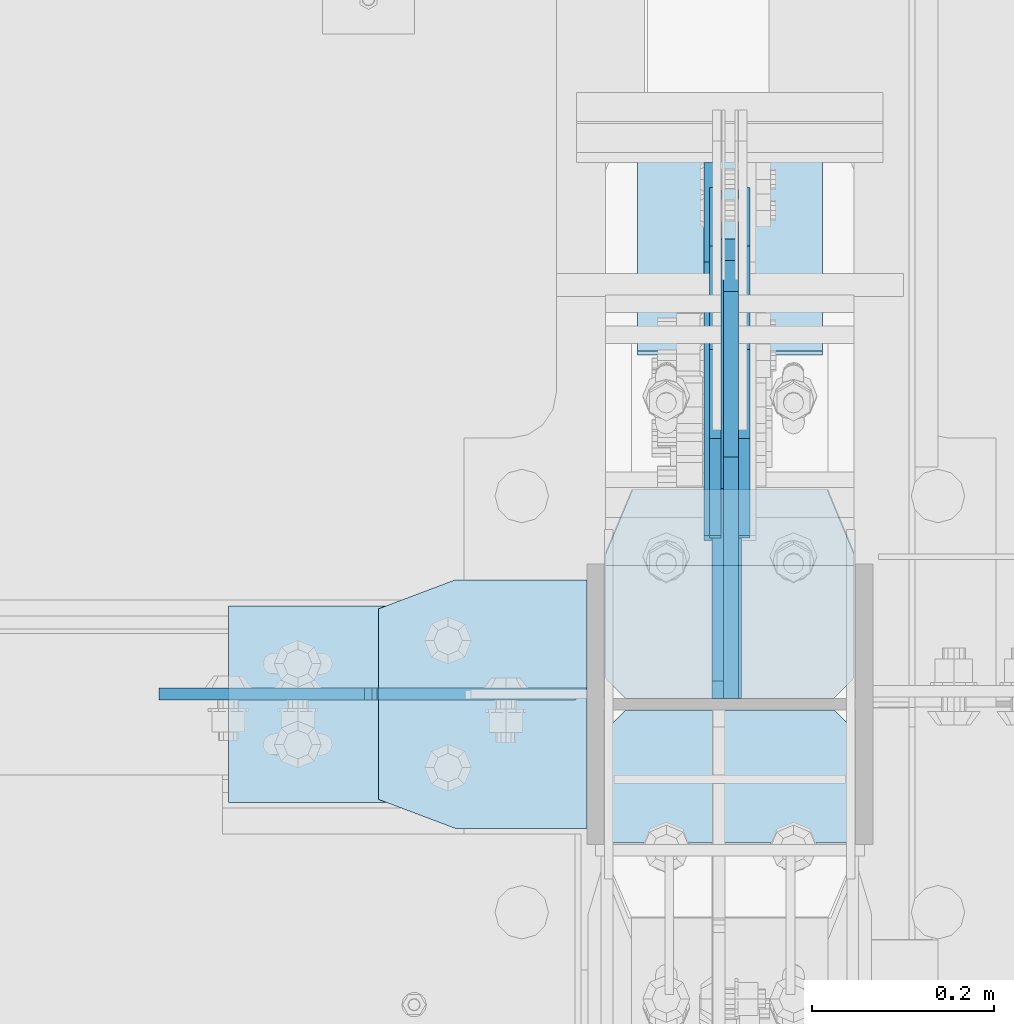
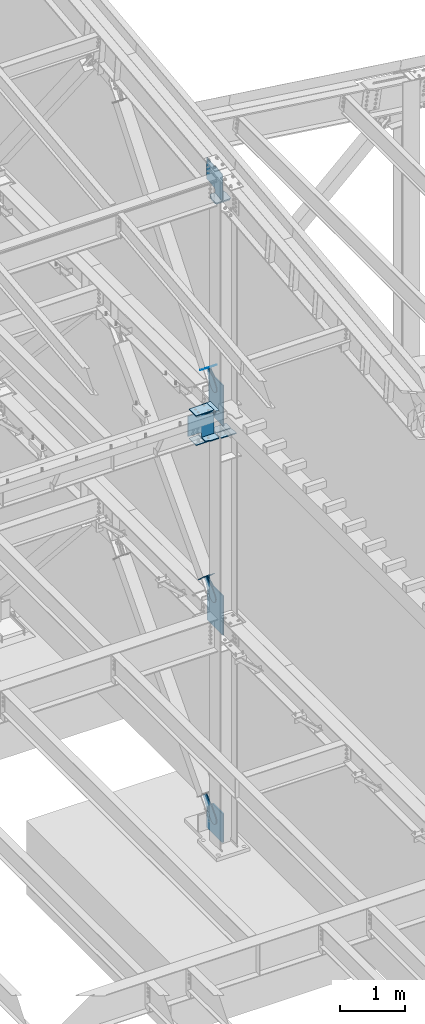
# One storey, part 1045 of 1179: 19 plates, 8 elements without a shape of their own.
"""IFC2X3 building model written with IfcOpenShell, lengths in millimetres."""

from ifc_helpers import new_model, si_unit, frame, origin_with_axes, place, context, subcontext, project, spatial, faceted_brep, material, type_object, element, aggregate, save


model = new_model("IFC2X3")

# Units and contexts
model_context = context("Model", 3, precision=1e-05, world=origin_with_axes())
body_context = subcontext(model_context, "Body", "Model", "MODEL_VIEW")
ifc_project = project(units=[si_unit("LENGTHUNIT", "METRE", prefix="MILLI"), si_unit("AREAUNIT", "SQUARE_METRE"), si_unit("VOLUMEUNIT", "CUBIC_METRE"), si_unit("MASSUNIT", "GRAM", prefix="KILO"), si_unit("TIMEUNIT", "SECOND"), si_unit("PLANEANGLEUNIT", "RADIAN"), si_unit("SOLIDANGLEUNIT", "STERADIAN"), si_unit("THERMODYNAMICTEMPERATUREUNIT", "DEGREE_CELSIUS"), si_unit("LUMINOUSINTENSITYUNIT", "LUMEN")], contexts=[model_context])

# Site, building, storey
site_placement = place(None, origin_with_axes())
site = spatial("IfcSite", under=ifc_project, at=site_placement, CompositionType="ELEMENT")
building_placement = place(site_placement, origin_with_axes())
building = spatial("IfcBuilding", under=site, at=building_placement, Name="Undefined", CompositionType="ELEMENT")
storey_placement = place(building_placement, origin_with_axes())
storey = spatial("IfcBuildingStorey", under=building, at=storey_placement, Name="Undefined", CompositionType="ELEMENT", Elevation=0.0)

# Assembly, plate
assembly_1_placement = place(storey_placement, origin_with_axes())
assembly_1 = element("IfcElementAssembly", 1, at=assembly_1_placement, inside=storey, AssemblyPlace="NOTDEFINED", PredefinedType="RIGID_FRAME")
ifc_material_1 = material(Name="STEEL/A36")
plate_type_1 = type_object("IfcPlateType", PredefinedType="NOTDEFINED")
plate_1_placement = place(assembly_1_placement, frame((24291.925, 27512.4985304241, 8313.50088383657), z_axis=(0.0, -0.784153429306141, 0.620566998242268), x_axis=(0.0, 0.62056699824227, 0.78415342930614)))
plate_1 = element("IfcPlate", 2, at=plate_1_placement, type_object=plate_type_1, material=ifc_material_1, context=body_context, shape_type="Brep", body=[
    faceted_brep([(0.0, -6.34999999999854, 0.0), (-101.600000000211, -6.34999999999854, -44.6881937825565), (-101.600000000211, 6.34999999999854, -44.6881937825565), (0.0, 6.34999999999854, 0.0), (-246.684985848258, -6.34999999999854, -44.6881937827675), (-246.684985848258, 6.34999999999854, -44.6881937827675), (-281.313054102191, -6.34999999999854, -37.800242748639), (-281.313054102191, 6.34999999999854, -37.800242748639), (-310.669312868691, -6.34999999999854, -18.1850177516608), (-310.669312868691, 6.34999999999854, -18.1850177516608), (-330.284537865713, -6.34999999999854, 11.1712410148393), (-330.284537865713, 6.34999999999854, 11.1712410148393), (-337.172488899912, -6.34999999999854, 45.7993031647638), (-337.172488899912, 6.34999999999854, 45.7993031647638), (-330.284537865768, -6.34999999999854, 80.4273714187839), (-330.284537865768, 6.34999999999854, 80.4273714187839), (-310.669312868773, -6.34999999999854, 109.783630185371), (-310.669312868773, 6.34999999999854, 109.783630185371), (-281.313054102271, -6.34999999999854, 129.398855182466), (-281.313054102271, 6.34999999999854, 129.398855182466), (-246.684988899762, -6.34999999999854, 136.286806216707), (-246.684988899762, 6.34999999999854, 136.286806216707), (-101.600000000377, -6.34999999999854, 136.286806216911), (-101.600000000377, 6.34999999999854, 136.286806216911), (-8.18545231595635e-11, -6.34999999999854, 91.5986124346418), (-8.18545231595635e-11, 6.34999999999854, 91.5986124346418), (67.3100000000013, -6.35000000000002, 91.5986124352912), (67.3100000000013, 6.35000000000002, 91.5986124352912), (67.309999999783, -6.35000000000002, -1.09139364212751e-11), (67.309999999783, 6.35000000000002, -1.09139364212751e-11)], [[[0, 1, 2, 3]], [[1, 4, 5, 2]], [[4, 6, 7, 5]], [[6, 8, 9, 7]], [[8, 10, 11, 9]], [[10, 12, 13, 11]], [[12, 14, 15, 13]], [[14, 16, 17, 15]], [[16, 18, 19, 17]], [[18, 20, 21, 19]], [[20, 22, 23, 21]], [[22, 24, 25, 23]], [[24, 26, 27, 25]], [[26, 28, 29, 27]], [[28, 0, 3, 29]], [[5, 7, 9, 11, 13, 15, 17, 19, 21, 23, 25, 27, 29, 3, 2]], [[28, 26, 24, 22, 20, 18, 16, 14, 12, 10, 8, 6, 4, 1, 0]]]),
])
aggregate(assembly_1, [plate_1])

assembly_2_placement = place(storey_placement, origin_with_axes())
assembly_2 = element("IfcElementAssembly", 3, at=assembly_2_placement, inside=storey, AssemblyPlace="NOTDEFINED", PredefinedType="RIGID_FRAME")
plate_2_placement = place(assembly_2_placement, frame((24323.675, 27512.4985304241, 8313.50088383657), z_axis=(0.0, -0.784153429306141, 0.620566998242268), x_axis=(0.0, 0.62056699824227, 0.78415342930614)))
plate_2 = element("IfcPlate", 4, at=plate_2_placement, type_object=plate_type_1, material=ifc_material_1, context=body_context, shape_type="Brep", body=[
    faceted_brep([(0.0, -6.34999999999854, 0.0), (-101.600000000211, -6.34999999999854, -44.6881937825565), (-101.600000000211, 6.34999999999854, -44.6881937825565), (0.0, 6.34999999999854, 0.0), (-246.684985848258, -6.34999999999854, -44.6881937827675), (-246.684985848258, 6.34999999999854, -44.6881937827675), (-281.313054102191, -6.34999999999854, -37.800242748639), (-281.313054102191, 6.34999999999854, -37.800242748639), (-310.669312868691, -6.34999999999854, -18.1850177516608), (-310.669312868691, 6.34999999999854, -18.1850177516608), (-330.284537865713, -6.34999999999854, 11.1712410148393), (-330.284537865713, 6.34999999999854, 11.1712410148393), (-337.172488899912, -6.34999999999854, 45.7993031647638), (-337.172488899912, 6.34999999999854, 45.7993031647638), (-330.284537865768, -6.34999999999854, 80.4273714187839), (-330.284537865768, 6.34999999999854, 80.4273714187839), (-310.669312868773, -6.34999999999854, 109.783630185371), (-310.669312868773, 6.34999999999854, 109.783630185371), (-281.313054102271, -6.34999999999854, 129.398855182466), (-281.313054102271, 6.34999999999854, 129.398855182466), (-246.684988899762, -6.34999999999854, 136.286806216707), (-246.684988899762, 6.34999999999854, 136.286806216707), (-101.600000000377, -6.34999999999854, 136.286806216911), (-101.600000000377, 6.34999999999854, 136.286806216911), (-8.18545231595635e-11, -6.34999999999854, 91.5986124346418), (-8.18545231595635e-11, 6.34999999999854, 91.5986124346418), (67.3100000000013, -6.35000000000002, 91.5986124352912), (67.3100000000013, 6.35000000000002, 91.5986124352912), (67.309999999783, -6.35000000000002, -1.09139364212751e-11), (67.309999999783, 6.35000000000002, -1.09139364212751e-11)], [[[0, 1, 2, 3]], [[1, 4, 5, 2]], [[4, 6, 7, 5]], [[6, 8, 9, 7]], [[8, 10, 11, 9]], [[10, 12, 13, 11]], [[12, 14, 15, 13]], [[14, 16, 17, 15]], [[16, 18, 19, 17]], [[18, 20, 21, 19]], [[20, 22, 23, 21]], [[22, 24, 25, 23]], [[24, 26, 27, 25]], [[26, 28, 29, 27]], [[28, 0, 3, 29]], [[5, 7, 9, 11, 13, 15, 17, 19, 21, 23, 25, 27, 29, 3, 2]], [[28, 26, 24, 22, 20, 18, 16, 14, 12, 10, 8, 6, 4, 1, 0]]]),
])
aggregate(assembly_2, [plate_2])

assembly_3_placement = place(storey_placement, origin_with_axes())
assembly_3 = element("IfcElementAssembly", 5, at=assembly_3_placement, inside=storey, Name="Plate", AssemblyPlace="NOTDEFINED", PredefinedType="RIGID_FRAME")
plate_type_2 = type_object("IfcPlateType", PredefinedType="NOTDEFINED")
plate_3_placement = place(assembly_3_placement, frame((24409.4, 27596.0549002431, 8329.164494984), z_axis=(0.0, -0.784153429306141, 0.620566998242268), x_axis=(-1.0, 0.0, 0.0)))
plate_3 = element("IfcPlate", 6, at=plate_3_placement, type_object=plate_type_2, material=ifc_material_1, Name="Plate", context=body_context, shape_type="Brep", body=[
    faceted_brep([(0.0, -3.17500000000109, 0.0), (0.0, -3.17500000000291, 203.200000000368), (0.0, 3.17499999998836, 203.200000000361), (0.0, 3.17500000000109, 7.27595761418343e-12), (203.199999999997, -3.17500000000291, 203.200000000368), (203.199999999997, 3.17499999998836, 203.200000000361), (203.199999999997, -3.17499999999927, 3.63797880709171e-12), (203.199999999997, 3.17499999999382, -3.63797880709171e-12)], [[[0, 1, 2, 3]], [[1, 4, 5, 2]], [[4, 6, 7, 5]], [[6, 0, 3, 7]], [[5, 7, 3, 2]], [[6, 4, 1, 0]]]),
])
aggregate(assembly_3, [plate_3])

assembly_4_placement = place(storey_placement, origin_with_axes())
assembly_4 = element("IfcElementAssembly", 7, at=assembly_4_placement, inside=storey, Name="Plate", AssemblyPlace="NOTDEFINED", PredefinedType="RIGID_FRAME")
plate_4_placement = place(assembly_4_placement, frame((24409.4, 27649.6818636391, 4382.10915283804), z_axis=(0.0, -0.729241792887682, 0.684256097894611), x_axis=(-1.0, 0.0, 0.0)))
plate_4 = element("IfcPlate", 8, at=plate_4_placement, type_object=plate_type_2, material=ifc_material_1, Name="Plate", context=body_context, shape_type="Brep", body=[
    faceted_brep([(0.0, -3.17500000000109, 0.0), (0.0, -3.17500000000291, 203.200000000368), (0.0, 3.17499999998836, 203.200000000361), (0.0, 3.17500000000109, 7.27595761418343e-12), (203.199999999997, -3.17500000000291, 203.200000000368), (203.199999999997, 3.17499999998836, 203.200000000361), (203.199999999997, -3.17499999999927, 3.63797880709171e-12), (203.199999999997, 3.17499999999382, -3.63797880709171e-12)], [[[0, 1, 2, 3]], [[1, 4, 5, 2]], [[4, 6, 7, 5]], [[6, 0, 3, 7]], [[5, 7, 3, 2]], [[6, 4, 1, 0]]]),
])
aggregate(assembly_4, [plate_4])

# Assembly, plates
assembly_5_placement = place(storey_placement, origin_with_axes())
assembly_5 = element("IfcElementAssembly", 9, at=assembly_5_placement, inside=storey, Name="COLUMN", AssemblyPlace="NOTDEFINED", PredefinedType="RIGID_FRAME")
ifc_material_2 = material(Name="STEEL/A572-GR.50")
plate_type_3 = type_object("IfcPlateType", PredefinedType="NOTDEFINED")
plate_5_placement = place(assembly_5_placement, frame((23922.0377761853, 27187.525, 7489.82500080334), z_axis=(0.0, -1.0, 0.0), x_axis=(1.0, 0.0, 0.0)))
plate_5 = element("IfcPlate", 10, at=plate_5_placement, type_object=plate_type_3, material=ifc_material_2, Name="PLATE", context=body_context, shape_type="Brep", body=[
    faceted_brep([(0.0, -9.52499999999964, 31.75), (-1.45519152283669e-11, -9.52499999999964, 241.299987792969), (1.81898940354586e-11, 9.52499999999964, 241.299987792969), (0.0, 9.52499999999964, 31.75), (84.1374969482276, -9.52499999999691, 273.049987792969), (84.1374969482604, 9.52500000000327, 273.049987792969), (228.599999999984, -9.52499999999054, 273.049987792969), (228.600000000017, 9.52500000000964, 273.049987792969), (228.599999999984, -9.52499999999054, 0.0), (228.600000000017, 9.52500000000964, 0.0), (84.1374969482276, -9.52499999999691, 0.0), (84.1374969482604, 9.52500000000327, 0.0)], [[[0, 1, 2, 3]], [[1, 4, 5, 2]], [[4, 6, 7, 5]], [[6, 8, 9, 7]], [[8, 10, 11, 9]], [[10, 0, 3, 11]], [[5, 7, 9, 11, 3, 2]], [[10, 8, 6, 4, 1, 0]]]),
])
plate_6_placement = place(assembly_5_placement, frame((23922.0377761853, 27187.525, 8004.17499919666), z_axis=(0.0, -1.0, 0.0), x_axis=(1.0, 0.0, 0.0)))
plate_6 = element("IfcPlate", 11, at=plate_6_placement, type_object=plate_type_3, material=ifc_material_2, Name="PLATE", context=body_context, shape_type="Brep", body=[
    faceted_brep([(0.0, -9.52499999999964, 31.75), (-1.45519152283669e-11, -9.52499999999964, 241.299987792969), (1.81898940354586e-11, 9.52499999999964, 241.299987792969), (0.0, 9.52499999999964, 31.75), (84.1374969482276, -9.52499999999691, 273.049987792969), (84.1374969482604, 9.52500000000327, 273.049987792969), (228.599999999984, -9.52499999999054, 273.049987792969), (228.600000000017, 9.52500000000964, 273.049987792969), (228.599999999984, -9.52499999999054, 0.0), (228.600000000017, 9.52500000000964, 0.0), (84.1374969482276, -9.52499999999691, 0.0), (84.1374969482604, 9.52500000000327, 0.0)], [[[0, 1, 2, 3]], [[1, 4, 5, 2]], [[4, 6, 7, 5]], [[6, 8, 9, 7]], [[8, 10, 11, 9]], [[10, 0, 3, 11]], [[5, 7, 9, 11, 3, 2]], [[10, 8, 6, 4, 1, 0]]]),
])
plate_type_4 = type_object("IfcPlateType", PredefinedType="NOTDEFINED")
plate_7_placement = place(assembly_5_placement, frame((24150.6375, 27062.1125, 7994.65), z_axis=(-1.0, 0.0, 0.0), x_axis=(0.0, 0.0, -1.0)))
plate_7 = element("IfcPlate", 12, at=plate_7_placement, type_object=plate_type_4, material=ifc_material_2, Name="PLATE", context=body_context, shape_type="Brep", body=[
    faceted_brep([(495.3, 6.34999999999854, 12.7000000000007), (495.3, -6.34999999999854, 0.0), (0.0, -6.34999999999854, 0.0), (0.0, 6.35000000000036, 12.6999999999571), (3.3701594188924, -6.34999999999854, 230.533183622028), (3.3701594188924, 6.34999999999854, 230.533183622028), (0.0, 6.34999999999854, 229.862817233581), (0.0, -6.34999999999854, 229.862817233581), (11.610512355127, -6.34999999999854, 236.039211422831), (11.610512355127, 6.34999999999854, 236.039211422831), (17.1165401561248, -6.34999999999854, 244.279564358931), (17.1165401561248, 6.34999999999854, 244.279564358931), (19.0500000014745, -6.34999999999854, 253.999723394838), (19.0500000014745, 6.34999999999854, 253.999723394838), (19.0500000066177, -6.34999999999854, 469.900000816731), (19.0500000066177, 6.34999999999854, 469.900000816429), (495.3, 6.34999999999854, 228.599723776602), (495.299999196217, -6.34999999999854, 228.599723776602), (425.449986692962, 6.34999999999854, 228.599723776479), (425.449986692962, -6.34999999999854, 228.599723776479), (415.729827637304, 6.34999999999854, 230.533183629737), (415.729827637304, -6.34999999999854, 230.533183629737), (407.489474690605, 6.34999999999854, 236.03921145252), (407.489474690605, -6.34999999999854, 236.03921145252), (401.983446895269, 6.34999999999854, 244.27956441756), (401.983446895269, -6.34999999999854, 244.27956441756), (400.049987074385, 6.34999999999854, 253.999723479657), (400.049987074385, -6.34999999999854, 253.999723479657), (400.049987793925, -6.34999999999854, 469.900000816429), (400.049987793925, 6.34999999999854, 469.900000816429), (0.0, -6.34999999999854, 228.599723776912), (0.0, 6.34999999999854, 228.599723776912)], [[[0, 1, 2, 3]], [[4, 5, 6, 7]], [[8, 9, 5, 4]], [[10, 11, 9, 8]], [[12, 13, 11, 10]], [[14, 15, 13, 12]], [[16, 17, 1, 0]], [[17, 16, 18, 19]], [[19, 18, 20, 21]], [[21, 20, 22, 23]], [[23, 22, 24, 25]], [[25, 24, 26, 27]], [[28, 27, 26, 29]], [[10, 8, 4, 7, 30, 2, 1, 17, 19, 21, 23, 25, 27, 28, 14, 12]], [[30, 7, 6, 31, 3, 2]], [[31, 6, 5, 9, 11, 13, 15, 29, 26, 24, 22, 20, 18, 16, 0, 3]], [[28, 29, 15, 14]]]),
])
plate_type_5 = type_object("IfcPlateType", PredefinedType="NOTDEFINED")
plate_8_placement = place(assembly_5_placement, frame((23756.9375009244, 27158.9499969482, 7473.95000087879), z_axis=(0.0, -1.0, 0.0), x_axis=(1.0, 0.0, 0.0)))
plate_8 = element("IfcPlate", 13, at=plate_8_placement, type_object=plate_type_5, material=ifc_material_2, Name="PLATE", context=body_context, shape_type="Brep", body=[
    faceted_brep([(0.0, -6.34999999999854, 0.0), (0.0, -6.350000000004, 215.899993896484), (0.0, 6.35000000000582, 215.899993896484), (0.0, 6.34999999999854, 0.0), (317.499999999996, -6.35000000014134, 215.899993896484), (317.5, 6.34999999985939, 215.899993896484), (317.499999999996, -6.35000000014134, 0.0), (317.5, 6.34999999985939, 0.0)], [[[0, 1, 2, 3]], [[1, 4, 5, 2]], [[4, 6, 7, 5]], [[6, 0, 3, 7]], [[5, 7, 3, 2]], [[6, 4, 1, 0]]]),
])
plate_9_placement = place(assembly_5_placement, frame((23756.9375009244, 27158.9499969482, 8020.04999912121), z_axis=(0.0, -1.0, 0.0), x_axis=(1.0, 0.0, 0.0)))
plate_9 = element("IfcPlate", 14, at=plate_9_placement, type_object=plate_type_5, material=ifc_material_2, Name="PLATE", context=body_context, shape_type="Brep", body=[
    faceted_brep([(0.0, -6.34999999999854, 0.0), (0.0, -6.350000000004, 215.899993896484), (0.0, 6.35000000000582, 215.899993896484), (0.0, 6.34999999999854, 0.0), (317.499999999996, -6.35000000014134, 215.899993896484), (317.5, 6.34999999985939, 215.899993896484), (317.499999999996, -6.35000000014134, 0.0), (317.5, 6.34999999985939, 0.0)], [[[0, 1, 2, 3]], [[1, 4, 5, 2]], [[4, 6, 7, 5]], [[6, 0, 3, 7]], [[5, 7, 3, 2]], [[6, 4, 1, 0]]]),
])
plate_type_6 = type_object("IfcPlateType", PredefinedType="NOTDEFINED")
plate_10_placement = place(assembly_5_placement, frame((24444.325, 27289.2635477102, 11792.0475823145), z_axis=(-1.0, 0.0, 0.0), x_axis=(0.0, -0.993676146336441, -0.112284087038017)))
plate_10 = element("IfcPlate", 15, at=plate_10_placement, type_object=plate_type_6, material=ifc_material_2, Name="PLATE", context=body_context, shape_type="Brep", body=[
    faceted_brep([(209.549999618157, -14.287499999904, 0.0), (73.0250015258425, -14.2874999999603, 0.0), (73.0250015258298, 14.2875000000258, 0.0), (209.549999618144, 14.2875000000804, 0.0), (231.774999999612, -14.2874999998949, 22.2250003814697), (231.774999999603, 14.2875000000895, 22.2250003814697), (231.774999999612, -14.2874999998949, 250.824999618533), (231.774999999603, 14.2875000000895, 250.824999618533), (209.549999618157, -14.287499999904, 273.050000000002), (209.549999618144, 14.2875000000804, 273.050000000002), (73.0250015258425, -14.2874999999603, 273.049999999998), (73.0250015258298, 14.2875000000258, 273.049999999998), (4.15974163581814, -14.2874999999876, 244.605653758279), (4.15974163581814, -14.2874999999876, 28.4443462417166), (0.930804522917242, 14.2874999999949, 29.7780376469105), (0.930804522917242, 14.2874999999949, 243.271962353085)], [[[0, 1, 2, 3]], [[4, 0, 3, 5]], [[6, 4, 5, 7]], [[8, 6, 7, 9]], [[10, 8, 9, 11]], [[1, 0, 4, 6, 8, 10, 12, 13]], [[2, 1, 13, 14]], [[11, 9, 7, 5, 3, 2, 14, 15]], [[10, 11, 15, 12]], [[14, 13, 12, 15]]]),
])
plate_type_7 = type_object("IfcPlateType", PredefinedType="NOTDEFINED")
plate_11_placement = place(assembly_5_placement, frame((24294.30625, 27057.35, 11799.2397941051), z_axis=(0.0, 0.663574933899741, 0.748109822886957), x_axis=(0.0, 0.748109822886957, -0.663574933899741)))
plate_11 = element("IfcPlate", 16, at=plate_11_placement, type_object=plate_type_7, material=ifc_material_2, Name="PLATE", context=body_context, shape_type="Brep", body=[
    faceted_brep([(-303.402323060972, -6.34999999999854, 370.580774758848), (-303.339376307906, 6.34999999999854, 370.524129968882), (-303.504098483867, 6.35000000000002, 342.168708916848), (-303.504098483867, -6.35000000000002, 342.168708916848), (25.4641550948563, -6.35000000000002, 0.0), (0.0, -6.34999999999854, 0.0), (0.0, 6.34999999999854, 0.0), (25.4641550948563, 6.35000000000002, 0.0), (167.045917247172, -6.35000000000002, 157.353263970723), (167.045917247172, 6.35000000000002, 157.353263970723), (131.563526715495, -6.35000000000002, 197.355899250204), (131.563526715495, 6.35000000000002, 197.355899250204), (126.802866418006, -6.35000000000002, 205.238730036501), (126.802866418006, 6.35000000000002, 205.238730036501), (125.165683086001, -6.35000000000002, 214.300878700633), (125.165683086001, 6.35000000000002, 214.300878700633), (126.867175912115, -6.35000000000002, 223.351173161929), (126.867175912115, 6.35000000000002, 223.351173161929), (131.683692556814, -6.35000000000002, 231.199999512715), (131.683692556814, 6.35000000000002, 231.199999512715), (286.794657668127, -6.35000000000002, 403.589566389341), (286.794657668127, 6.35000000000002, 403.589566389341), (23.8827060644498, -6.35000000000002, 699.99493122035), (23.8827060644498, 6.35000000000002, 699.99493122035), (-127.388721232707, -6.35000000000002, 531.872607863961), (-127.388721232707, 6.35000000000002, 531.872607863961), (-134.060951024564, -6.35000000000002, 526.588932486246), (-134.060951024564, 6.35000000000002, 526.588932486246), (-142.104023886786, -6.35000000000002, 523.805974558898), (-142.104023886786, 6.35000000000002, 523.805974558898), (-150.614897093323, -6.35000000000002, 523.836193008534), (-150.614897093323, 6.35000000000002, 523.836193008534), (-158.638005243585, -6.35000000000002, 526.676195033468), (-158.638005243585, 6.35000000000002, 526.676195033468), (-161.065417892858, 6.35000000000002, 528.626645817876), (-161.065417892858, -6.35000000000002, 528.626645817876)], [[[0, 1, 2, 3]], [[4, 5, 6, 7]], [[8, 4, 7, 9]], [[10, 8, 9, 11]], [[12, 10, 11, 13]], [[14, 12, 13, 15]], [[16, 14, 15, 17]], [[18, 16, 17, 19]], [[20, 18, 19, 21]], [[22, 20, 21, 23]], [[24, 22, 23, 25]], [[26, 24, 25, 27]], [[28, 26, 27, 29]], [[30, 28, 29, 31]], [[32, 30, 31, 33]], [[32, 33, 34, 35]], [[5, 4, 8, 10, 12, 14, 16, 18, 20, 22, 24, 26, 28, 30, 32, 35, 0, 3]], [[6, 5, 3, 2]], [[34, 33, 31, 29, 27, 25, 23, 21, 19, 17, 15, 13, 11, 9, 7, 6, 2, 1]], [[35, 34, 1, 0]]]),
])
plate_type_8 = type_object("IfcPlateType", PredefinedType="NOTDEFINED")
plate_12_placement = place(assembly_5_placement, frame((24444.325, 27044.65, 7488.2375), z_axis=(-1.0, 0.0, 0.0), x_axis=(0.0, -1.0, 0.0)))
plate_12 = element("IfcPlate", 17, at=plate_12_placement, type_object=plate_type_8, material=ifc_material_2, Name="PLATE", context=body_context, shape_type="Brep", body=[
    faceted_brep([(0.0, -7.9375, 22.2250003814697), (0.0, -7.9375, 250.824987411499), (0.0, 7.9375, 250.824987411499), (0.0, 7.9375, 22.2250003814697), (22.2250003814697, -7.9375, 273.049987792969), (22.2250003814697, 7.9375, 273.049987792969), (146.050003051758, -7.9375, 273.049987792969), (146.050003051758, 7.9375, 273.049987792969), (146.050003051758, -7.9375, 0.0), (146.050003051758, 7.9375, 0.0), (22.2250003814697, -7.9375, 0.0), (22.2250003814697, 7.9375, 0.0)], [[[0, 1, 2, 3]], [[1, 4, 5, 2]], [[4, 6, 7, 5]], [[6, 8, 9, 7]], [[8, 10, 11, 9]], [[10, 0, 3, 11]], [[5, 7, 9, 11, 3, 2]], [[10, 8, 6, 4, 1, 0]]]),
])
plate_13_placement = place(assembly_5_placement, frame((24444.325, 27203.4, 7488.2375), z_axis=(-1.0, 0.0, 0.0), x_axis=(0.0, -1.0, 0.0)))
plate_13 = element("IfcPlate", 18, at=plate_13_placement, type_object=plate_type_8, material=ifc_material_2, Name="PLATE", context=body_context, shape_type="Brep", body=[
    faceted_brep([(0.0, -7.9375, 0.0), (0.0, -7.9375, 273.049987792969), (0.0, 7.9375, 273.049987792969), (0.0, 7.9375, 0.0), (123.825002670288, -7.9375, 273.049987792969), (123.825002670288, 7.9375, 273.049987792969), (146.050003051758, -7.9375, 250.824987411499), (146.050003051758, 7.9375, 250.824987411499), (146.050003051758, -7.9375, 22.2250003814697), (146.050003051758, 7.9375, 22.2250003814697), (123.825002670288, -7.9375, 0.0), (123.825002670288, 7.9375, 0.0)], [[[0, 1, 2, 3]], [[1, 4, 5, 2]], [[4, 6, 7, 5]], [[6, 8, 9, 7]], [[8, 10, 11, 9]], [[10, 0, 3, 11]], [[5, 7, 9, 11, 3, 2]], [[10, 8, 6, 4, 1, 0]]]),
])

# Assembly, plate
assembly_6_placement = place(storey_placement, origin_with_axes())
assembly_6 = element("IfcElementAssembly", 19, at=assembly_6_placement, inside=storey, AssemblyPlace="NOTDEFINED", PredefinedType="RIGID_FRAME")
plate_type_9 = type_object("IfcPlateType", PredefinedType="NOTDEFINED")
plate_14_placement = place(assembly_6_placement, frame((24291.925, 27562.1830397494, 4355.36439357567), z_axis=(0.0, -0.729241792887682, 0.684256097894611), x_axis=(0.0, 0.684256097894612, 0.729241792887681)))
plate_14 = element("IfcPlate", 20, at=plate_14_placement, type_object=plate_type_9, material=ifc_material_1, context=body_context, shape_type="Brep", body=[
    faceted_brep([(0.0, -6.34999999999854, 0.0), (-101.599999999963, -6.34999999999854, -37.5700345970108), (-101.599999999963, 6.34999999999854, -37.5700345970108), (0.0, 6.34999999999854, 0.0), (-245.369242323884, -6.34999999999854, -37.5700345970945), (-245.369242323884, 6.34999999999854, -37.5700345970945), (-281.212328723803, -6.34999999999854, -30.4404014271258), (-281.212328723803, 6.34999999999854, -30.4404014271258), (-311.598630137756, -6.34999999999854, -10.1369239370142), (-311.598630137756, 6.34999999999854, -10.1369239370142), (-331.902107627997, -6.34999999999854, 20.24937747687), (-331.902107627997, 6.34999999999854, 20.24937747687), (-339.031740798124, -6.34999999999854, 56.0924669287269), (-339.031740798124, 6.34999999999854, 56.0924669287269), (-331.902107628228, -6.34999999999854, 91.9355533287926), (-331.902107628228, 6.34999999999854, 91.9355533287926), (-311.598630138099, -6.34999999999854, 122.321854742866), (-311.598630138099, 6.34999999999854, 122.321854742866), (-281.212328724136, -6.34999999999854, 142.625332233139), (-281.212328724136, 6.34999999999854, 142.625332233139), (-245.36924079839, -6.34999999999854, 149.754965403199), (-245.36924079839, 6.34999999999854, 149.754965403199), (-101.600000000685, -6.34999999999854, 149.75496540329), (-101.600000000685, 6.34999999999854, 149.75496540329), (-4.35647962149233e-10, -6.34999999999854, 112.184930806416), (-4.35647962149233e-10, 6.34999999999854, 112.184930806416), (82.5499999996491, -6.34999999999854, 112.184930806461), (82.5499999996491, 6.34999999999854, 112.184930806461), (82.550000000203, -6.34999999999854, 1.2732925824821e-10), (82.550000000203, 6.34999999999854, 1.2732925824821e-10)], [[[0, 1, 2, 3]], [[1, 4, 5, 2]], [[4, 6, 7, 5]], [[6, 8, 9, 7]], [[8, 10, 11, 9]], [[10, 12, 13, 11]], [[12, 14, 15, 13]], [[14, 16, 17, 15]], [[16, 18, 19, 17]], [[18, 20, 21, 19]], [[20, 22, 23, 21]], [[22, 24, 25, 23]], [[24, 26, 27, 25]], [[26, 28, 29, 27]], [[28, 0, 3, 29]], [[5, 7, 9, 11, 13, 15, 17, 19, 21, 23, 25, 27, 29, 3, 2]], [[28, 26, 24, 22, 20, 18, 16, 14, 12, 10, 8, 6, 4, 1, 0]]]),
])
aggregate(assembly_6, [plate_14])

assembly_7_placement = place(storey_placement, origin_with_axes())
assembly_7 = element("IfcElementAssembly", 21, at=assembly_7_placement, inside=storey, AssemblyPlace="NOTDEFINED", PredefinedType="RIGID_FRAME")
plate_15_placement = place(assembly_7_placement, frame((24323.675, 27562.1830397494, 4355.36439357567), z_axis=(0.0, -0.729241792887682, 0.684256097894611), x_axis=(0.0, 0.684256097894612, 0.729241792887681)))
plate_15 = element("IfcPlate", 22, at=plate_15_placement, type_object=plate_type_9, material=ifc_material_1, context=body_context, shape_type="Brep", body=[
    faceted_brep([(0.0, -6.34999999999854, 0.0), (-101.599999999963, -6.34999999999854, -37.5700345970108), (-101.599999999963, 6.34999999999854, -37.5700345970108), (0.0, 6.34999999999854, 0.0), (-245.369242323884, -6.34999999999854, -37.5700345970945), (-245.369242323884, 6.34999999999854, -37.5700345970945), (-281.212328723803, -6.34999999999854, -30.4404014271258), (-281.212328723803, 6.34999999999854, -30.4404014271258), (-311.598630137756, -6.34999999999854, -10.1369239370142), (-311.598630137756, 6.34999999999854, -10.1369239370142), (-331.902107627997, -6.34999999999854, 20.24937747687), (-331.902107627997, 6.34999999999854, 20.24937747687), (-339.031740798124, -6.34999999999854, 56.0924669287269), (-339.031740798124, 6.34999999999854, 56.0924669287269), (-331.902107628228, -6.34999999999854, 91.9355533287926), (-331.902107628228, 6.34999999999854, 91.9355533287926), (-311.598630138099, -6.34999999999854, 122.321854742866), (-311.598630138099, 6.34999999999854, 122.321854742866), (-281.212328724136, -6.34999999999854, 142.625332233139), (-281.212328724136, 6.34999999999854, 142.625332233139), (-245.36924079839, -6.34999999999854, 149.754965403199), (-245.36924079839, 6.34999999999854, 149.754965403199), (-101.600000000685, -6.34999999999854, 149.75496540329), (-101.600000000685, 6.34999999999854, 149.75496540329), (-4.35647962149233e-10, -6.34999999999854, 112.184930806416), (-4.35647962149233e-10, 6.34999999999854, 112.184930806416), (82.5499999996491, -6.34999999999854, 112.184930806461), (82.5499999996491, 6.34999999999854, 112.184930806461), (82.550000000203, -6.34999999999854, 1.2732925824821e-10), (82.550000000203, 6.34999999999854, 1.2732925824821e-10)], [[[0, 1, 2, 3]], [[1, 4, 5, 2]], [[4, 6, 7, 5]], [[6, 8, 9, 7]], [[8, 10, 11, 9]], [[10, 12, 13, 11]], [[12, 14, 15, 13]], [[14, 16, 17, 15]], [[16, 18, 19, 17]], [[18, 20, 21, 19]], [[20, 22, 23, 21]], [[22, 24, 25, 23]], [[24, 26, 27, 25]], [[26, 28, 29, 27]], [[28, 0, 3, 29]], [[5, 7, 9, 11, 13, 15, 17, 19, 21, 23, 25, 27, 29, 3, 2]], [[28, 26, 24, 22, 20, 18, 16, 14, 12, 10, 8, 6, 4, 1, 0]]]),
])
aggregate(assembly_7, [plate_15])

# Plate
plate_type_10 = type_object("IfcPlateType", PredefinedType="NOTDEFINED")
plate_16_placement = place(assembly_5_placement, frame((24307.8, 27057.35, 7575.55), z_axis=(0.0, 0.0, 1.0), x_axis=(0.0, 1.0, 0.0)))
plate_16 = element("IfcPlate", 23, at=plate_16_placement, type_object=plate_type_10, material=ifc_material_2, Name="PLATE", context=body_context, shape_type="Brep", body=[
    faceted_brep([(0.0, -9.52499999999964, 0.0), (0.0, -9.52500000000146, 758.618391409447), (0.0, 9.52500000000146, 758.618391409447), (0.0, 9.52499999999964, 0.0), (265.31165983442, -9.52500000000146, 758.618391409447), (265.31165983442, 9.52500000000146, 758.618391409447), (447.05882091185, -9.52500000000146, 614.786475391844), (447.05882091185, 9.52500000000146, 614.786475391844), (447.05882091185, -9.52500000000146, 0.0), (447.05882091185, 9.52500000000146, 0.0)], [[[0, 1, 2, 3]], [[1, 4, 5, 2]], [[4, 6, 7, 5]], [[6, 8, 9, 7]], [[8, 0, 3, 9]], [[5, 7, 9, 3, 2]], [[8, 6, 4, 1, 0]]]),
])

plate_type_11 = type_object("IfcPlateType", PredefinedType="NOTDEFINED")
plate_17_placement = place(assembly_5_placement, frame((24307.8, 27057.35, 3663.95), z_axis=(0.0, 0.0, 1.0), x_axis=(0.0, 1.0, 0.0)))
plate_17 = element("IfcPlate", 24, at=plate_17_placement, type_object=plate_type_11, material=ifc_material_2, Name="PLATE", context=body_context, shape_type="Brep", body=[
    faceted_brep([(0.0, -9.52499999999964, 0.0), (0.0, -9.52499999999998, 737.174280571875), (0.0, 9.52499999999998, 737.174280571875), (0.0, 9.52499999999964, 0.0), (307.582299199603, -9.52499999999998, 737.174280571875), (307.582299199603, 9.52499999999998, 737.174280571875), (481.233001130982, -9.52499999999998, 574.235797260721), (481.233001130982, 9.52499999999998, 574.235797260721), (481.233001130982, -9.52499999999998, 0.0), (481.233001130982, 9.52499999999998, 0.0)], [[[0, 1, 2, 3]], [[1, 4, 5, 2]], [[4, 6, 7, 5]], [[6, 8, 9, 7]], [[8, 0, 3, 9]], [[5, 7, 9, 3, 2]], [[8, 6, 4, 1, 0]]]),
])

plate_type_12 = type_object("IfcPlateType", PredefinedType="NOTDEFINED")
plate_18_placement = place(assembly_5_placement, frame((24307.8, 27057.35, -215.899999999999), z_axis=(0.0, 0.0, 1.0), x_axis=(0.0, 1.0, 0.0)))
plate_18 = element("IfcPlate", 25, at=plate_18_placement, type_object=plate_type_12, material=ifc_material_2, Name="PLATE", context=body_context, shape_type="Brep", body=[
    faceted_brep([(0.0, -12.7000000000007, 19.0500000000029), (0.0, -12.7, 551.799398203347), (0.0, 12.7, 551.799398203347), (0.0, 12.7000000000007, 19.0500000000029), (324.819501230952, -12.7, 551.799398203347), (324.819501230952, 12.7, 551.799398203347), (504.769838076878, -12.7, 391.040055491836), (504.769838076878, 12.7, 391.040055491836), (504.769838076878, -12.7, 0.0), (504.769838076878, 12.7, 0.0), (19.0499992370605, -12.6999999999971, 0.0), (19.0499992370605, 12.6999999999971, 0.0)], [[[0, 1, 2, 3]], [[1, 4, 5, 2]], [[4, 6, 7, 5]], [[6, 8, 9, 7]], [[8, 10, 11, 9]], [[10, 0, 3, 11]], [[5, 7, 9, 11, 3, 2]], [[10, 8, 6, 4, 1, 0]]]),
])

aggregate(assembly_5, [plate_10, plate_11, plate_8, plate_5, plate_9, plate_6, plate_12, plate_13, plate_7, plate_16, plate_17, plate_18])

# Assembly, plate
assembly_8_placement = place(storey_placement, origin_with_axes())
assembly_8 = element("IfcElementAssembly", 26, at=assembly_8_placement, inside=storey, AssemblyPlace="NOTDEFINED", PredefinedType="RIGID_FRAME")
plate_type_13 = type_object("IfcPlateType", PredefinedType="NOTDEFINED")
plate_19_placement = place(assembly_8_placement, frame((24287.1625, 27594.6102194491, 282.352678620124), z_axis=(0.0, -0.74575357167811, 0.666221892712438), x_axis=(0.0, 0.666221892712437, 0.74575357167811)))
plate_19 = element("IfcPlate", 27, at=plate_19_placement, type_object=plate_type_13, material=ifc_material_1, context=body_context, shape_type="Brep", body=[
    faceted_brep([(0.0, -7.9375, 0.0), (-101.600000000497, -7.9375, -21.7975798445477), (-101.600000000497, 7.9375, -21.7975798445477), (0.0, 7.9375, 0.0), (-320.921138851689, -7.9375, -21.7975798443877), (-320.921138851689, 7.9375, -21.7975798443877), (-357.371735784433, -7.9375, -14.5471053160727), (-357.371735784433, 7.9375, -14.5471053160727), (-388.273059759649, -7.9375, 6.10049924760824), (-388.273059759649, 7.9375, 6.10049924760824), (-408.920664323319, -7.9375, 37.0018232228431), (-408.920664323319, 7.9375, 37.0018232228431), (-416.171138851623, -7.9375, 73.4524201546446), (-416.171138851623, 7.9375, 73.4524201546446), (-408.920664323337, -7.9375, 109.903017087447), (-408.920664323337, 7.9375, 109.903017087447), (-388.273059759656, -7.9375, 140.804341062707), (-388.273059759656, 7.9375, 140.804341062707), (-357.3717357844, -7.9375, 161.451945626395), (-357.3717357844, 7.9375, 161.451945626395), (-320.921138851201, -7.9375, 168.702420154674), (-320.921138851201, 7.9375, 168.702420154674), (-101.600000000592, -7.9375, 168.702420154521), (-101.600000000592, 7.9375, 168.702420154521), (-8.00355337560177e-11, -7.9375, 146.904840309817), (-8.00355337560177e-11, 7.9375, 146.904840309817), (77.4700000003613, -7.9375, 146.904840309813), (77.4700000003613, 7.9375, 146.904840309813), (77.4700000003904, -7.9375, -5.82076609134674e-11), (77.4700000003904, 7.9375, -5.82076609134674e-11)], [[[0, 1, 2, 3]], [[1, 4, 5, 2]], [[4, 6, 7, 5]], [[6, 8, 9, 7]], [[8, 10, 11, 9]], [[10, 12, 13, 11]], [[12, 14, 15, 13]], [[14, 16, 17, 15]], [[16, 18, 19, 17]], [[18, 20, 21, 19]], [[20, 22, 23, 21]], [[22, 24, 25, 23]], [[24, 26, 27, 25]], [[26, 28, 29, 27]], [[28, 0, 3, 29]], [[5, 7, 9, 11, 13, 15, 17, 19, 21, 23, 25, 27, 29, 3, 2]], [[28, 26, 24, 22, 20, 18, 16, 14, 12, 10, 8, 6, 4, 1, 0]]]),
])
aggregate(assembly_8, [plate_19])

save(model, "model.ifc")
